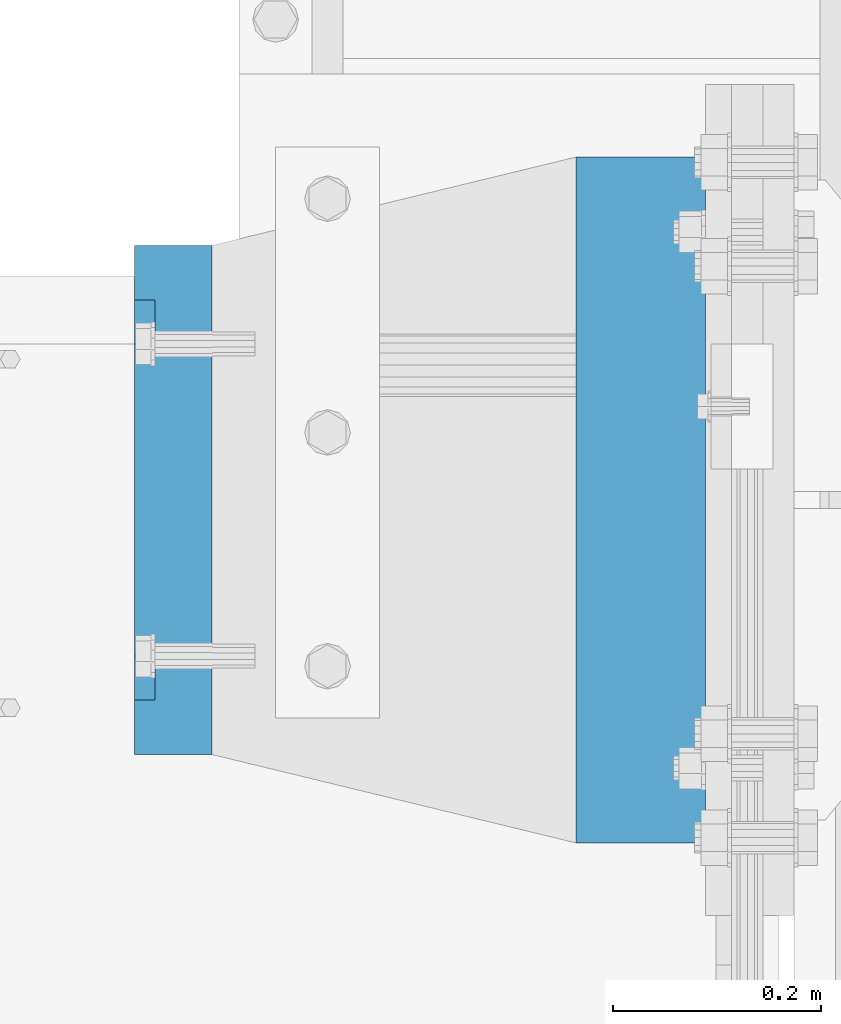
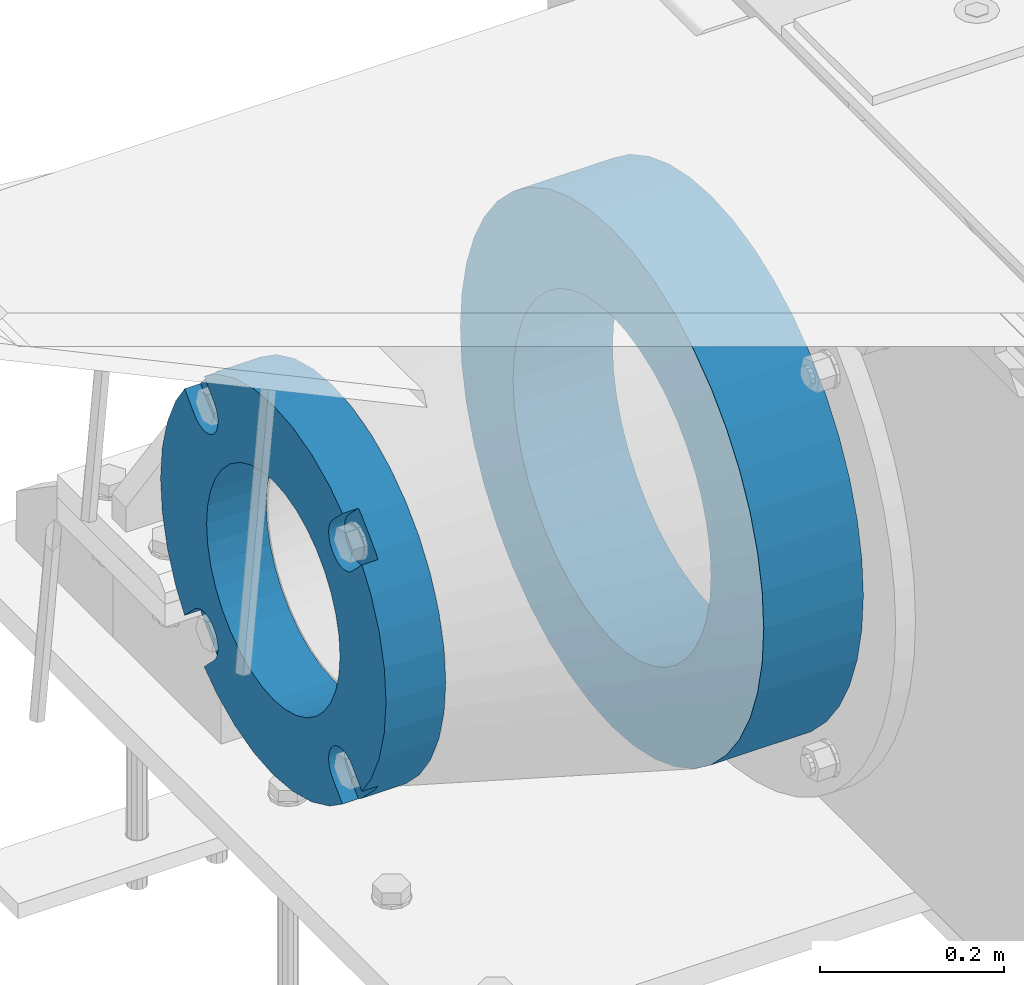
# One storey, part 120 of 208: 2 beams.
"""IFC2X3 building model written with IfcOpenShell, lengths in millimetres."""

from ifc_helpers import new_model, si_unit, frame, origin_with_axes, place, context, subcontext, project, spatial, faceted_brep, material, type_object, element, save


model = new_model("IFC2X3")

# Units and contexts
model_context = context("Model", 3, precision=1e-05, world=origin_with_axes())
body_context = subcontext(model_context, "Body", "Model", "MODEL_VIEW")
ifc_project = project(units=[si_unit("LENGTHUNIT", "METRE", prefix="MILLI"), si_unit("AREAUNIT", "SQUARE_METRE"), si_unit("VOLUMEUNIT", "CUBIC_METRE"), si_unit("MASSUNIT", "GRAM", prefix="KILO"), si_unit("TIMEUNIT", "SECOND"), si_unit("PLANEANGLEUNIT", "RADIAN"), si_unit("SOLIDANGLEUNIT", "STERADIAN"), si_unit("THERMODYNAMICTEMPERATUREUNIT", "DEGREE_CELSIUS"), si_unit("LUMINOUSINTENSITYUNIT", "LUMEN")], contexts=[model_context])

# Site, building, storey
site_placement = place(None, origin_with_axes())
site = spatial("IfcSite", under=ifc_project, at=site_placement, CompositionType="ELEMENT")
building_placement = place(site_placement, origin_with_axes())
building = spatial("IfcBuilding", under=site, at=building_placement, Name="Standard", CompositionType="ELEMENT")
storey_placement = place(building_placement, origin_with_axes())
storey = spatial("IfcBuildingStorey", under=building, at=storey_placement, Name="Undefined", CompositionType="ELEMENT", Elevation=0.0)

# Beams
ifc_material_1 = material(Name="SCN-500-E2")
beam_type_1 = type_object("IfcBeamType", PredefinedType="NOTDEFINED")
beam_1_placement = place(storey_placement, frame((-43000.0, 6000.00000146624, -515.0), z_axis=(0.0, 0.0, 1.0), x_axis=(-1.0, 0.0, 0.0)))
element("IfcBeam", 1, at=beam_1_placement, inside=storey, type_object=beam_type_1, material=ifc_material_1, context=body_context, shape_type="Brep", body=[
    faceted_brep([(75.0, 192.717024793295, -150.290616455866), (75.0, 171.473395903973, -129.046987566545), (55.0, 171.473395903973, -129.046987566545), (55.0, 192.717024793295, -150.290616455866), (75.0, 167.467485558908, -125.685629673471), (55.0, 167.467485558908, -125.685629673471), (75.0, 162.938740320598, -123.070957391042), (55.0, 162.938740320598, -123.070957391042), (75.0, 158.024763821452, -121.282416213469), (55.0, 158.024763821452, -121.282416213469), (75.0, 152.874864750806, -120.374350059389), (55.0, 152.874864750806, -120.374350059389), (75.0, 147.645520185947, -120.374350059389), (55.0, 147.645520185947, -120.374350059389), (75.0, 142.495621115301, -121.282416213469), (55.0, 142.495621115301, -121.282416213469), (75.0, 137.581644616156, -123.070957391042), (55.0, 137.581644616156, -123.070957391042), (75.0, 133.052899377845, -125.685629673471), (55.0, 133.052899377845, -125.685629673471), (75.0, 129.04698903278, -129.046987566545), (55.0, 129.04698903278, -129.046987566545), (75.0, 125.685631139707, -133.05289791161), (55.0, 125.685631139707, -133.05289791161), (75.0, 123.070958857277, -137.58164314992), (55.0, 123.070958857277, -137.58164314992), (75.0, 121.282417679705, -142.495619649066), (55.0, 121.282417679705, -142.495619649066), (75.0, 120.374351525625, -147.645518719712), (55.0, 120.374351525625, -147.645518719712), (75.0, 120.374351525625, -152.874863284571), (55.0, 120.374351525625, -152.874863284571), (75.0, 121.282417679705, -158.024762355217), (55.0, 121.282417679705, -158.024762355217), (75.0, 123.070958857277, -162.938738854362), (55.0, 123.070958857277, -162.938738854362), (75.0, 125.685631139707, -167.467484092673), (55.0, 125.685631139707, -167.467484092673), (75.0, 129.04698903278, -171.473394437738), (55.0, 129.04698903278, -171.473394437738), (55.0, 150.290618180638, -192.717023585596), (75.0, 150.290618180639, -192.717023585596), (55.0, 157.482964373202, -187.68088856415), (55.0, 187.680888564149, -157.482964373202), (75.0, -192.717023585596, 150.29061818064), (75.0, -171.4733929715, 129.046987566545), (55.0, -171.4733929715, 129.046987566545), (55.0, -192.717023585596, 150.29061818064), (75.0, -167.467482626435, 125.685629673472), (55.0, -167.467482626435, 125.685629673472), (75.0, -162.938737388125, 123.070957391042), (55.0, -162.938737388125, 123.070957391042), (75.0, -158.024760888979, 121.282416213469), (55.0, -158.024760888979, 121.282416213469), (75.0, -152.874861818334, 120.374350059389), (55.0, -152.874861818334, 120.374350059389), (75.0, -147.645517253474, 120.374350059389), (55.0, -147.645517253474, 120.374350059389), (75.0, -142.495618182828, 121.282416213469), (55.0, -142.495618182828, 121.282416213469), (75.0, -137.581641683683, 123.070957391042), (55.0, -137.581641683683, 123.070957391042), (75.0, -133.052896445372, 125.685629673472), (55.0, -133.052896445372, 125.685629673472), (75.0, -129.046986100308, 129.046987566545), (55.0, -129.046986100308, 129.046987566545), (75.0, -125.685628207234, 133.05289791161), (55.0, -125.685628207234, 133.05289791161), (75.0, -123.070955924804, 137.58164314992), (55.0, -123.070955924804, 137.58164314992), (75.0, -121.282414747232, 142.495619649066), (55.0, -121.282414747232, 142.495619649066), (75.0, -120.374348593152, 147.645518719712), (55.0, -120.374348593152, 147.645518719712), (75.0, -120.374348593152, 152.874863284571), (55.0, -120.374348593152, 152.874863284571), (75.0, -121.282414747232, 158.024762355217), (55.0, -121.282414747232, 158.024762355217), (75.0, -123.070955924804, 162.938738854362), (55.0, -123.070955924804, 162.938738854362), (75.0, -125.685628207234, 167.467484092673), (55.0, -125.685628207234, 167.467484092673), (75.0, -129.046986100308, 171.473394437738), (55.0, -129.046986100308, 171.473394437738), (55.0, -150.290616455865, 192.717024793295), (75.0, -150.290616455866, 192.717024793295), (75.0, 150.290618180638, 192.717023585596), (75.0000000000073, 129.04698903278, 171.473394437739), (55.0, 129.04698903278, 171.473394437739), (55.0, 150.290618180638, 192.717023585597), (75.0000000000073, 125.685631139707, 167.467484092674), (55.0, 125.685631139707, 167.467484092674), (75.0000000000073, 123.070958857277, 162.938738854364), (55.0, 123.070958857277, 162.938738854364), (75.0000000000073, 121.282417679705, 158.024762355218), (55.0, 121.282417679705, 158.024762355218), (75.0000000000073, 120.374351525625, 152.874863284572), (55.0, 120.374351525625, 152.874863284572), (75.0000000000073, 120.374351525625, 147.645518719713), (55.0, 120.374351525625, 147.645518719713), (75.0000000000073, 121.282417679705, 142.495619649067), (55.0, 121.282417679705, 142.495619649067), (75.0000000000073, 123.070958857277, 137.581643149922), (55.0, 123.070958857277, 137.581643149922), (75.0000000000073, 125.685631139707, 133.052897911611), (55.0, 125.685631139707, 133.052897911611), (75.0000000000073, 129.04698903278, 129.046987566546), (55.0, 129.04698903278, 129.046987566546), (75.0000000000073, 133.052899377845, 125.685629673473), (55.0, 133.052899377845, 125.685629673473), (75.0000000000073, 137.581644616156, 123.070957391043), (55.0, 137.581644616156, 123.070957391043), (75.0000000000073, 142.495621115301, 121.282416213471), (55.0, 142.495621115301, 121.282416213471), (75.0000000000073, 147.645520185947, 120.37435005939), (55.0, 147.645520185947, 120.37435005939), (75.0000000000073, 152.874864750806, 120.37435005939), (55.0, 152.874864750806, 120.37435005939), (75.0000000000073, 158.024763821452, 121.282416213471), (55.0, 158.024763821452, 121.282416213471), (75.0000000000073, 162.938740320597, 123.070957391043), (55.0, 162.938740320597, 123.070957391043), (75.0000000000073, 167.467485558908, 125.685629673473), (55.0, 167.467485558908, 125.685629673473), (75.0000000000073, 171.473395903973, 129.046987566546), (55.0, 171.473395903973, 129.046987566546), (55.0, 192.717024793295, 150.290616455867), (75.0, 192.717024793294, 150.290616455868), (0.0, 212.176223927187, -122.5), (0.0, 230.224692092547, -83.7949351147888), (75.0, 230.224692092547, -83.7949351147888), (75.0, 212.176223927187, -122.5), (0.0, 241.277899487991, -42.5438035283978), (75.0, 241.277899487991, -42.5438035283978), (0.0, 245.0, 0.0), (75.0, 245.0, 0.0), (0.0, 241.277899487991, 42.543803528398), (75.0, 241.277899487991, 42.543803528398), (0.0, 230.224692092547, 83.7949351147889), (75.0, 230.224692092547, 83.7949351147889), (0.0, 212.176223927187, 122.5), (75.0, 212.176223927187, 122.5), (0.0, 187.680888564149, 157.482964373202), (55.0, 187.680888564149, 157.482964373202), (0.0, 157.482964373202, 187.68088856415), (55.0, 157.482964373202, 187.68088856415), (0.0, 122.5, 212.176223927187), (75.0, 122.5, 212.176223927187), (0.0, 83.794935114789, 230.224692092548), (75.0, 83.794935114789, 230.224692092548), (0.0, 42.5438035283978, 241.277899487991), (75.0, 42.5438035283978, 241.277899487991), (0.0, 0.0, 245.0), (75.0, 0.0, 245.0), (0.0, -42.5438035283978, 241.277899487991), (75.0, -42.5438035283978, 241.277899487991), (0.0, -83.794935114789, 230.224692092548), (75.0, -83.794935114789, 230.224692092548), (0.0, -122.5, 212.176223927187), (75.0, -122.5, 212.176223927187), (0.0, -157.482964373202, 187.68088856415), (55.0, -157.482964373202, 187.68088856415), (0.0, -187.680888564149, 157.482964373202), (55.0, -187.680888564149, 157.482964373202), (0.0, -212.176223927187, 122.5), (75.0, -212.176223927187, 122.5), (0.0, -230.224692092547, 83.7949351147888), (75.0, -230.224692092547, 83.7949351147888), (0.0, -241.277899487991, 42.5438035283979), (75.0, -241.277899487991, 42.5438035283979), (0.0, -245.0, 0.0), (75.0, -245.0, 0.0), (0.0, -187.680888564149, -157.482964373202), (0.0, -157.482964373202, -187.68088856415), (55.0, -157.482964373202, -187.68088856415), (55.0, -187.680888564149, -157.482964373202), (0.0, 83.794935114789, -230.224692092547), (0.0, 122.5, -212.176223927187), (75.0, 122.5, -212.176223927187), (75.0, 83.794935114789, -230.224692092547), (0.0, 42.5438035283978, -241.277899487991), (75.0, 42.5438035283978, -241.277899487991), (0.0, 0.0, -245.0), (75.0, 0.0, -245.0), (0.0, -42.5438035283978, -241.277899487991), (75.0, -42.5438035283978, -241.277899487991), (0.0, -83.794935114789, -230.224692092548), (75.0, -83.794935114789, -230.224692092548), (0.0, -122.5, -212.176223927187), (75.0, -122.5, -212.176223927187), (75.0, -150.290616455864, -192.717024793296), (55.0, -150.290616455864, -192.717024793296), (55.0, -129.046986100308, -171.473394437739), (55.0, -125.685628207234, -167.467484092674), (55.0, -123.070955924804, -162.938738854364), (55.0, -121.282414747232, -158.024762355218), (55.0, -120.374348593152, -152.874863284572), (55.0, -120.374348593152, -147.645518719713), (55.0, -121.282414747232, -142.495619649067), (55.0, -123.070955924804, -137.581643149922), (55.0, -125.685628207234, -133.052897911611), (55.0, -129.046986100308, -129.046987566546), (55.0, -133.052896445372, -125.685629673473), (55.0, -137.581641683683, -123.070957391043), (55.0, -142.495618182828, -121.282416213471), (55.0, -147.645517253474, -120.37435005939), (55.0, -152.874861818334, -120.37435005939), (55.0, -158.024760888979, -121.282416213471), (55.0, -162.938737388125, -123.070957391043), (55.0, -167.467482626435, -125.685629673473), (55.0, -171.4733929715, -129.046987566546), (55.0, -192.717023585595, -150.29061818064), (75.0, -129.046986100308, -171.473394437739), (75.0, -125.685628207234, -167.467484092674), (75.0, -123.070955924804, -162.938738854364), (75.0, -121.282414747232, -158.024762355218), (75.0, -120.374348593152, -152.874863284572), (75.0, -120.374348593152, -147.645518719713), (75.0, -121.282414747232, -142.495619649067), (75.0, -123.070955924804, -137.581643149922), (75.0, -125.685628207234, -133.052897911611), (75.0, -129.046986100308, -129.046987566546), (75.0, -133.052896445372, -125.685629673473), (75.0, -137.581641683683, -123.070957391043), (75.0, -142.495618182828, -121.282416213471), (75.0, -147.645517253474, -120.37435005939), (75.0, -152.874861818334, -120.37435005939), (75.0, -158.024760888979, -121.282416213471), (75.0, -162.938737388125, -123.070957391043), (75.0, -167.467482626435, -125.685629673473), (75.0, -171.4733929715, -129.046987566546), (75.0, -192.717023585595, -150.290618180641), (75.0, -212.176223927187, -122.5), (0.0, -212.176223927187, -122.5), (0.0, -230.224692092547, -83.794935114789), (75.0, -230.224692092547, -83.794935114789), (0.0, -241.277899487991, -42.5438035283979), (75.0, -241.277899487991, -42.5438035283979), (0.0, 187.680888564149, -157.482964373202), (0.0, 157.482964373202, -187.68088856415), (0.0, -142.79712418677, -25.1789857617049), (0.0, -136.255430013956, -49.592920782222), (0.0, -125.573683548743, -72.5), (0.0, -111.076444252252, -93.2042034045483), (0.0, -93.204203404548, -111.076444252252), (0.0, -72.5, -125.573683548744), (0.0, -49.5929207822219, -136.255430013957), (0.0, -25.178985761705, -142.79712418677), (0.0, 0.0, -145.0), (0.0, 25.178985761705, -142.79712418677), (0.0, 49.5929207822219, -136.255430013957), (0.0, 72.5, -125.573683548744), (0.0, 93.204203404548, -111.076444252252), (0.0, 111.076444252251, -93.2042034045483), (0.0, 125.573683548743, -72.5), (0.0, 136.255430013956, -49.592920782222), (0.0, 142.79712418677, -25.178985761705), (0.0, 145.0, 0.0), (0.0, 142.79712418677, 25.1789857617048), (0.0, 136.255430013956, 49.5929207822219), (0.0, 125.573683548743, 72.4999999999999), (0.0, 111.076444252252, 93.2042034045482), (0.0, 93.204203404548, 111.076444252252), (0.0, 72.5, 125.573683548744), (0.0, 49.5929207822219, 136.255430013957), (0.0, 25.178985761705, 142.79712418677), (0.0, 0.0, 145.0), (0.0, -25.178985761705, 142.79712418677), (0.0, -49.5929207822219, 136.255430013957), (0.0, -72.5, 125.573683548744), (0.0, -93.204203404548, 111.076444252252), (0.0, -111.076444252251, 93.2042034045483), (0.0, -125.573683548743, 72.5000000000001), (0.0, -136.255430013956, 49.5929207822221), (0.0, -142.79712418677, 25.1789857617049), (0.0, -145.0, 0.0), (75.0, -145.0, 0.0), (75.0, -142.79712418677, -25.1789857617049), (75.0, -136.255430013956, -49.592920782222), (75.0, -125.573683548743, -72.5), (75.0, -111.076444252252, -93.2042034045483), (75.0, -93.204203404548, -111.076444252252), (75.0, -72.5, -125.573683548744), (75.0, -49.5929207822219, -136.255430013957), (75.0, -25.178985761705, -142.79712418677), (75.0, 0.0, -145.0), (75.0, 25.178985761705, -142.79712418677), (75.0, 49.5929207822219, -136.255430013957), (75.0, 72.5, -125.573683548744), (75.0, 93.204203404548, -111.076444252252), (75.0, 111.076444252251, -93.2042034045483), (75.0, 125.573683548743, -72.5), (75.0, 136.255430013956, -49.592920782222), (75.0, 142.79712418677, -25.178985761705), (75.0, 145.0, 0.0), (75.0, 142.79712418677, 25.1789857617048), (75.0, 136.255430013956, 49.5929207822219), (75.0, 125.573683548743, 72.4999999999999), (75.0, 111.076444252252, 93.2042034045482), (75.0, 93.204203404548, 111.076444252252), (75.0, 72.5, 125.573683548744), (75.0, 49.5929207822219, 136.255430013957), (75.0, 25.178985761705, 142.79712418677), (75.0, 0.0, 145.0), (75.0, -25.178985761705, 142.79712418677), (75.0, -49.5929207822219, 136.255430013957), (75.0, -72.5, 125.573683548744), (75.0, -93.204203404548, 111.076444252252), (75.0, -111.076444252251, 93.2042034045483), (75.0, -125.573683548743, 72.5000000000001), (75.0, -136.255430013956, 49.5929207822221), (75.0, -142.79712418677, 25.1789857617049)], [[[0, 1, 2, 3]], [[4, 5, 2, 1]], [[6, 7, 5, 4]], [[8, 9, 7, 6]], [[10, 11, 9, 8]], [[12, 13, 11, 10]], [[14, 15, 13, 12]], [[16, 17, 15, 14]], [[18, 19, 17, 16]], [[20, 21, 19, 18]], [[22, 23, 21, 20]], [[24, 25, 23, 22]], [[26, 27, 25, 24]], [[28, 29, 27, 26]], [[30, 31, 29, 28]], [[32, 33, 31, 30]], [[34, 35, 33, 32]], [[36, 37, 35, 34]], [[38, 39, 37, 36]], [[40, 39, 38, 41]], [[42, 43, 3, 2, 5, 7, 9, 11, 13, 15, 17, 19, 21, 23, 25, 27, 29, 31, 33, 35, 37, 39, 40]], [[44, 45, 46, 47]], [[48, 49, 46, 45]], [[50, 51, 49, 48]], [[52, 53, 51, 50]], [[54, 55, 53, 52]], [[56, 57, 55, 54]], [[58, 59, 57, 56]], [[60, 61, 59, 58]], [[62, 63, 61, 60]], [[64, 65, 63, 62]], [[66, 67, 65, 64]], [[68, 69, 67, 66]], [[70, 71, 69, 68]], [[72, 73, 71, 70]], [[74, 75, 73, 72]], [[76, 77, 75, 74]], [[78, 79, 77, 76]], [[80, 81, 79, 78]], [[82, 83, 81, 80]], [[84, 83, 82, 85]], [[86, 87, 88, 89]], [[90, 91, 88, 87]], [[92, 93, 91, 90]], [[94, 95, 93, 92]], [[96, 97, 95, 94]], [[98, 99, 97, 96]], [[100, 101, 99, 98]], [[102, 103, 101, 100]], [[104, 105, 103, 102]], [[106, 107, 105, 104]], [[108, 109, 107, 106]], [[110, 111, 109, 108]], [[112, 113, 111, 110]], [[114, 115, 113, 112]], [[116, 117, 115, 114]], [[118, 119, 117, 116]], [[120, 121, 119, 118]], [[122, 123, 121, 120]], [[124, 125, 123, 122]], [[126, 125, 124, 127]], [[128, 129, 130, 131]], [[129, 132, 133, 130]], [[132, 134, 135, 133]], [[134, 136, 137, 135]], [[136, 138, 139, 137]], [[138, 140, 141, 139]], [[127, 141, 140, 142, 143, 126]], [[142, 144, 145, 143]], [[89, 88, 91, 93, 95, 97, 99, 101, 103, 105, 107, 109, 111, 113, 115, 117, 119, 121, 123, 125, 126, 143, 145]], [[144, 146, 147, 86, 89, 145]], [[146, 148, 149, 147]], [[148, 150, 151, 149]], [[150, 152, 153, 151]], [[152, 154, 155, 153]], [[154, 156, 157, 155]], [[156, 158, 159, 157]], [[85, 159, 158, 160, 161, 84]], [[160, 162, 163, 161]], [[47, 46, 49, 51, 53, 55, 57, 59, 61, 63, 65, 67, 69, 71, 73, 75, 77, 79, 81, 83, 84, 161, 163]], [[162, 164, 165, 44, 47, 163]], [[164, 166, 167, 165]], [[166, 168, 169, 167]], [[168, 170, 171, 169]], [[172, 173, 174, 175]], [[176, 177, 178, 179]], [[180, 176, 179, 181]], [[182, 180, 181, 183]], [[184, 182, 183, 185]], [[186, 184, 185, 187]], [[188, 186, 187, 189]], [[173, 188, 189, 190, 191, 174]], [[175, 174, 191, 192, 193, 194, 195, 196, 197, 198, 199, 200, 201, 202, 203, 204, 205, 206, 207, 208, 209, 210, 211]], [[190, 212, 192, 191]], [[213, 193, 192, 212]], [[214, 194, 193, 213]], [[215, 195, 194, 214]], [[216, 196, 195, 215]], [[217, 197, 196, 216]], [[218, 198, 197, 217]], [[219, 199, 198, 218]], [[220, 200, 199, 219]], [[221, 201, 200, 220]], [[222, 202, 201, 221]], [[223, 203, 202, 222]], [[224, 204, 203, 223]], [[225, 205, 204, 224]], [[226, 206, 205, 225]], [[227, 207, 206, 226]], [[228, 208, 207, 227]], [[229, 209, 208, 228]], [[230, 210, 209, 229]], [[211, 210, 230, 231]], [[232, 233, 172, 175, 211, 231]], [[234, 233, 232, 235]], [[236, 234, 235, 237]], [[170, 236, 237, 171]], [[168, 166, 164, 162, 160, 158, 156, 154, 152, 150, 148, 146, 144, 142, 140, 138, 136, 134, 132, 129, 128, 238, 239, 177, 176, 180, 182, 184, 186, 188, 173, 172, 233, 234, 236, 170], [240, 241, 242, 243, 244, 245, 246, 247, 248, 249, 250, 251, 252, 253, 254, 255, 256, 257, 258, 259, 260, 261, 262, 263, 264, 265, 266, 267, 268, 269, 270, 271, 272, 273, 274, 275]], [[240, 275, 276, 277]], [[241, 240, 277, 278]], [[242, 241, 278, 279]], [[243, 242, 279, 280]], [[244, 243, 280, 281]], [[245, 244, 281, 282]], [[246, 245, 282, 283]], [[247, 246, 283, 284]], [[248, 247, 284, 285]], [[249, 248, 285, 286]], [[250, 249, 286, 287]], [[251, 250, 287, 288]], [[252, 251, 288, 289]], [[253, 252, 289, 290]], [[254, 253, 290, 291]], [[255, 254, 291, 292]], [[256, 255, 292, 293]], [[257, 256, 293, 294]], [[258, 257, 294, 295]], [[259, 258, 295, 296]], [[260, 259, 296, 297]], [[261, 260, 297, 298]], [[262, 261, 298, 299]], [[263, 262, 299, 300]], [[264, 263, 300, 301]], [[265, 264, 301, 302]], [[266, 265, 302, 303]], [[267, 266, 303, 304]], [[268, 267, 304, 305]], [[269, 268, 305, 306]], [[270, 269, 306, 307]], [[271, 270, 307, 308]], [[272, 271, 308, 309]], [[273, 272, 309, 310]], [[274, 273, 310, 311]], [[275, 274, 311, 276]], [[24, 22, 20, 18, 16, 14, 12, 10, 8, 6, 4, 1, 0, 131, 130, 133, 135, 137, 139, 141, 127, 124, 122, 120, 118, 116, 114, 112, 110, 108, 106, 104, 102, 100, 98, 96, 94, 92, 90, 87, 86, 147, 149, 151, 153, 155, 157, 159, 85, 82, 80, 78, 76, 74, 72, 70, 68, 66, 64, 62, 60, 58, 56, 54, 52, 50, 48, 45, 44, 165, 167, 169, 171, 237, 235, 232, 231, 230, 229, 228, 227, 226, 225, 224, 223, 222, 221, 220, 219, 218, 217, 216, 215, 214, 213, 212, 190, 189, 187, 185, 183, 181, 179, 178, 41, 38, 36, 34, 32, 30, 28, 26], [310, 309, 308, 307, 306, 305, 304, 303, 302, 301, 300, 299, 298, 297, 296, 295, 294, 293, 292, 291, 290, 289, 288, 287, 286, 285, 284, 283, 282, 281, 280, 279, 278, 277, 276, 311]], [[238, 128, 131, 0, 3, 43]], [[239, 238, 43, 42]], [[178, 177, 239, 42, 40, 41]]]),
])
ifc_material_2 = material(Name="STEEL/S355N")
beam_type_2 = type_object("IfcBeamType", PredefinedType="NOTDEFINED")
beam_2_placement = place(storey_placement, frame((-42525.0, 6000.0, -515.0), z_axis=(0.0, 0.0, 1.0), x_axis=(-1.0, 0.0, 0.0)))
element("IfcBeam", 2, at=beam_2_placement, inside=storey, type_object=beam_type_2, material=ifc_material_2, context=body_context, shape_type="Brep", body=[
    faceted_brep([(0.0, -215.0, 0.0), (0.0, -212.811610004401, 30.5976902287563), (125.0, -212.811610004401, 30.5976902287563), (125.0, -215.0, 0.0), (0.0, -206.290989327117, 60.5724997209074), (125.0, -206.290989327117, 60.5724997209074), (0.0, -195.570879001221, 89.3142277954056), (125.0, -195.570879001221, 89.3142277954056), (0.0, -180.869509558704, 116.237775752953), (125.0, -180.869509558704, 116.237775752953), (0.0, -162.486158486166, 140.795057798236), (125.0, -162.486158486166, 140.795057798236), (0.0, -140.795057798236, 162.486158486165), (125.0, -140.795057798236, 162.486158486165), (0.0, -116.237775752953, 180.869509558704), (125.0, -116.237775752953, 180.869509558704), (0.0, -89.3142277954057, 195.570879001222), (125.0, -89.3142277954057, 195.570879001222), (0.0, -60.5724997209072, 206.290989327117), (125.0, -60.5724997209072, 206.290989327117), (0.0, -30.5976902287566, 212.811610004401), (125.0, -30.5976902287566, 212.811610004401), (0.0, 0.0, 215.0), (125.0, 0.0, 215.0), (0.0, 30.5976902287566, 212.811610004401), (125.0, 30.5976902287566, 212.811610004401), (0.0, 60.5724997209072, 206.290989327117), (125.0, 60.5724997209072, 206.290989327117), (0.0, 89.3142277954057, 195.570879001221), (125.0, 89.3142277954057, 195.570879001221), (0.0, 116.237775752954, 180.869509558704), (125.0, 116.237775752954, 180.869509558704), (0.0, 140.795057798236, 162.486158486165), (125.0, 140.795057798236, 162.486158486165), (0.0, 162.486158486166, 140.795057798236), (125.0, 162.486158486166, 140.795057798236), (0.0, 180.869509558704, 116.237775752953), (125.0, 180.869509558704, 116.237775752953), (0.0, 195.570879001221, 89.3142277954056), (125.0, 195.570879001221, 89.3142277954056), (0.0, 206.290989327117, 60.5724997209073), (125.0, 206.290989327117, 60.5724997209073), (0.0, 212.811610004401, 30.5976902287563), (125.0, 212.811610004401, 30.5976902287563), (0.0, 215.0, 0.0), (125.0, 215.0, 0.0), (0.0, 212.811610004401, -30.5976902287563), (125.0, 212.811610004401, -30.5976902287563), (0.0, 206.290989327117, -60.5724997209073), (125.0, 206.290989327117, -60.5724997209073), (0.0, 195.570879001221, -89.3142277954056), (125.0, 195.570879001221, -89.3142277954056), (0.0, 180.869509558704, -116.237775752954), (125.0, 180.869509558704, -116.237775752954), (0.0, 162.486158486166, -140.795057798236), (125.0, 162.486158486166, -140.795057798236), (0.0, 140.795057798236, -162.486158486166), (125.0, 140.795057798236, -162.486158486166), (0.0, 116.237775752954, -180.869509558704), (125.0, 116.237775752954, -180.869509558704), (0.0, 89.3142277954057, -195.570879001221), (125.0, 89.3142277954057, -195.570879001221), (0.0, 60.5724997209072, -206.290989327117), (125.0, 60.5724997209072, -206.290989327117), (0.0, 30.5976902287566, -212.811610004401), (125.0, 30.5976902287566, -212.811610004401), (0.0, 0.0, -215.0), (125.0, 0.0, -215.0), (0.0, -30.5976902287566, -212.811610004401), (125.0, -30.5976902287566, -212.811610004401), (0.0, -60.5724997209072, -206.290989327117), (125.0, -60.5724997209072, -206.290989327117), (0.0, -89.3142277954057, -195.570879001221), (125.0, -89.3142277954057, -195.570879001221), (0.0, -116.237775752954, -180.869509558704), (125.0, -116.237775752954, -180.869509558704), (0.0, -140.795057798236, -162.486158486166), (125.0, -140.795057798236, -162.486158486166), (0.0, -162.486158486166, -140.795057798236), (125.0, -162.486158486166, -140.795057798236), (0.0, -180.869509558704, -116.237775752953), (125.0, -180.869509558704, -116.237775752953), (0.0, -195.570879001221, -89.3142277954056), (125.0, -195.570879001221, -89.3142277954056), (0.0, -206.290989327117, -60.5724997209073), (125.0, -206.290989327117, -60.5724997209073), (0.0, -212.811610004401, -30.5976902287563), (125.0, -212.811610004401, -30.5976902287563), (0.0, -330.0, 0.0), (0.0, -326.641075820708, -46.9638966301842), (125.0, -326.641075820708, -46.9638966301842), (125.0, -330.0, 0.0), (0.0, -316.632681292784, -92.9717437576718), (125.0, -316.632681292784, -92.9717437576718), (0.0, -300.178558466991, -137.086954290623), (125.0, -300.178558466991, -137.086954290623), (0.0, -277.613665834289, -178.411469760347), (125.0, -277.613665834289, -178.411469760347), (0.0, -249.397359536905, -216.104042201944), (125.0, -249.397359536905, -216.104042201944), (0.0, -216.104042201944, -249.397359536905), (125.0, -216.104042201944, -249.397359536905), (0.0, -178.411469760347, -277.61366583429), (125.0, -178.411469760347, -277.61366583429), (0.0, -137.086954290622, -300.178558466991), (125.0, -137.086954290622, -300.178558466991), (0.0, -92.9717437576719, -316.632681292784), (125.0, -92.9717437576719, -316.632681292784), (0.0, -46.9638966301836, -326.641075820708), (125.0, -46.9638966301836, -326.641075820708), (0.0, 0.0, -330.0), (125.0, 0.0, -330.0), (0.0, 46.9638966301845, -326.641075820708), (125.0, 46.9638966301845, -326.641075820708), (0.0, 92.9717437576719, -316.632681292784), (125.0, 92.9717437576719, -316.632681292784), (0.0, 137.086954290622, -300.178558466991), (125.0, 137.086954290622, -300.178558466991), (0.0, 178.411469760347, -277.61366583429), (125.0, 178.411469760347, -277.61366583429), (0.0, 216.104042201944, -249.397359536905), (125.0, 216.104042201944, -249.397359536905), (0.0, 249.397359536905, -216.104042201944), (125.0, 249.397359536905, -216.104042201944), (0.0, 277.613665834289, -178.411469760347), (125.0, 277.613665834289, -178.411469760347), (0.0, 300.178558466991, -137.086954290623), (125.0, 300.178558466991, -137.086954290623), (0.0, 316.632681292785, -92.9717437576717), (125.0, 316.632681292785, -92.9717437576717), (0.0, 326.641075820708, -46.9638966301841), (125.0, 326.641075820708, -46.9638966301841), (0.0, 330.0, 0.0), (125.0, 330.0, 0.0), (0.0, 326.641075820708, 46.9638966301841), (125.0, 326.641075820708, 46.9638966301841), (0.0, 316.632681292784, 92.9717437576718), (125.0, 316.632681292784, 92.9717437576718), (0.0, 300.178558466991, 137.086954290622), (125.0, 300.178558466991, 137.086954290622), (0.0, 277.613665834289, 178.411469760347), (125.0, 277.613665834289, 178.411469760347), (0.0, 249.397359536905, 216.104042201944), (125.0, 249.397359536905, 216.104042201944), (0.0, 216.104042201944, 249.397359536905), (125.0, 216.104042201944, 249.397359536905), (0.0, 178.411469760347, 277.61366583429), (125.0, 178.411469760347, 277.61366583429), (0.0, 137.086954290622, 300.178558466991), (125.0, 137.086954290622, 300.178558466991), (0.0, 92.9717437576719, 316.632681292784), (125.0, 92.9717437576719, 316.632681292784), (0.0, 46.9638966301836, 326.641075820708), (125.0, 46.9638966301836, 326.641075820708), (0.0, 0.0, 330.0), (125.0, 0.0, 330.0), (0.0, -46.9638966301845, 326.641075820708), (125.0, -46.9638966301845, 326.641075820708), (0.0, -92.9717437576719, 316.632681292784), (125.0, -92.9717437576719, 316.632681292784), (0.0, -137.086954290622, 300.178558466991), (125.0, -137.086954290622, 300.178558466991), (0.0, -178.411469760347, 277.61366583429), (125.0, -178.411469760347, 277.61366583429), (0.0, -216.104042201944, 249.397359536905), (125.0, -216.104042201944, 249.397359536905), (0.0, -249.397359536905, 216.104042201944), (125.0, -249.397359536905, 216.104042201944), (0.0, -277.613665834289, 178.411469760347), (125.0, -277.613665834289, 178.411469760347), (0.0, -300.178558466991, 137.086954290623), (125.0, -300.178558466991, 137.086954290623), (0.0, -316.632681292784, 92.9717437576718), (125.0, -316.632681292784, 92.9717437576718), (0.0, -326.641075820708, 46.9638966301841), (125.0, -326.641075820708, 46.9638966301841)], [[[0, 1, 2, 3]], [[1, 4, 5, 2]], [[4, 6, 7, 5]], [[6, 8, 9, 7]], [[8, 10, 11, 9]], [[10, 12, 13, 11]], [[12, 14, 15, 13]], [[14, 16, 17, 15]], [[16, 18, 19, 17]], [[18, 20, 21, 19]], [[20, 22, 23, 21]], [[22, 24, 25, 23]], [[24, 26, 27, 25]], [[26, 28, 29, 27]], [[28, 30, 31, 29]], [[30, 32, 33, 31]], [[32, 34, 35, 33]], [[34, 36, 37, 35]], [[36, 38, 39, 37]], [[38, 40, 41, 39]], [[40, 42, 43, 41]], [[42, 44, 45, 43]], [[44, 46, 47, 45]], [[46, 48, 49, 47]], [[48, 50, 51, 49]], [[50, 52, 53, 51]], [[52, 54, 55, 53]], [[54, 56, 57, 55]], [[56, 58, 59, 57]], [[58, 60, 61, 59]], [[60, 62, 63, 61]], [[62, 64, 65, 63]], [[64, 66, 67, 65]], [[66, 68, 69, 67]], [[68, 70, 71, 69]], [[70, 72, 73, 71]], [[72, 74, 75, 73]], [[74, 76, 77, 75]], [[76, 78, 79, 77]], [[78, 80, 81, 79]], [[80, 82, 83, 81]], [[82, 84, 85, 83]], [[84, 86, 87, 85]], [[86, 0, 3, 87]], [[88, 89, 90, 91]], [[89, 92, 93, 90]], [[92, 94, 95, 93]], [[94, 96, 97, 95]], [[96, 98, 99, 97]], [[98, 100, 101, 99]], [[100, 102, 103, 101]], [[102, 104, 105, 103]], [[104, 106, 107, 105]], [[106, 108, 109, 107]], [[108, 110, 111, 109]], [[110, 112, 113, 111]], [[112, 114, 115, 113]], [[114, 116, 117, 115]], [[116, 118, 119, 117]], [[118, 120, 121, 119]], [[120, 122, 123, 121]], [[122, 124, 125, 123]], [[124, 126, 127, 125]], [[126, 128, 129, 127]], [[128, 130, 131, 129]], [[130, 132, 133, 131]], [[132, 134, 135, 133]], [[134, 136, 137, 135]], [[136, 138, 139, 137]], [[138, 140, 141, 139]], [[140, 142, 143, 141]], [[142, 144, 145, 143]], [[144, 146, 147, 145]], [[146, 148, 149, 147]], [[148, 150, 151, 149]], [[150, 152, 153, 151]], [[152, 154, 155, 153]], [[154, 156, 157, 155]], [[156, 158, 159, 157]], [[158, 160, 161, 159]], [[160, 162, 163, 161]], [[162, 164, 165, 163]], [[164, 166, 167, 165]], [[166, 168, 169, 167]], [[168, 170, 171, 169]], [[170, 172, 173, 171]], [[172, 174, 175, 173]], [[174, 88, 91, 175]], [[93, 95, 97, 99, 101, 103, 105, 107, 109, 111, 113, 115, 117, 119, 121, 123, 125, 127, 129, 131, 133, 135, 137, 139, 141, 143, 145, 147, 149, 151, 153, 155, 157, 159, 161, 163, 165, 167, 169, 171, 173, 175, 91, 90], [5, 7, 9, 11, 13, 15, 17, 19, 21, 23, 25, 27, 29, 31, 33, 35, 37, 39, 41, 43, 45, 47, 49, 51, 53, 55, 57, 59, 61, 63, 65, 67, 69, 71, 73, 75, 77, 79, 81, 83, 85, 87, 3, 2]], [[174, 172, 170, 168, 166, 164, 162, 160, 158, 156, 154, 152, 150, 148, 146, 144, 142, 140, 138, 136, 134, 132, 130, 128, 126, 124, 122, 120, 118, 116, 114, 112, 110, 108, 106, 104, 102, 100, 98, 96, 94, 92, 89, 88], [86, 84, 82, 80, 78, 76, 74, 72, 70, 68, 66, 64, 62, 60, 58, 56, 54, 52, 50, 48, 46, 44, 42, 40, 38, 36, 34, 32, 30, 28, 26, 24, 22, 20, 18, 16, 14, 12, 10, 8, 6, 4, 1, 0]]]),
])

save(model, "model.ifc")
